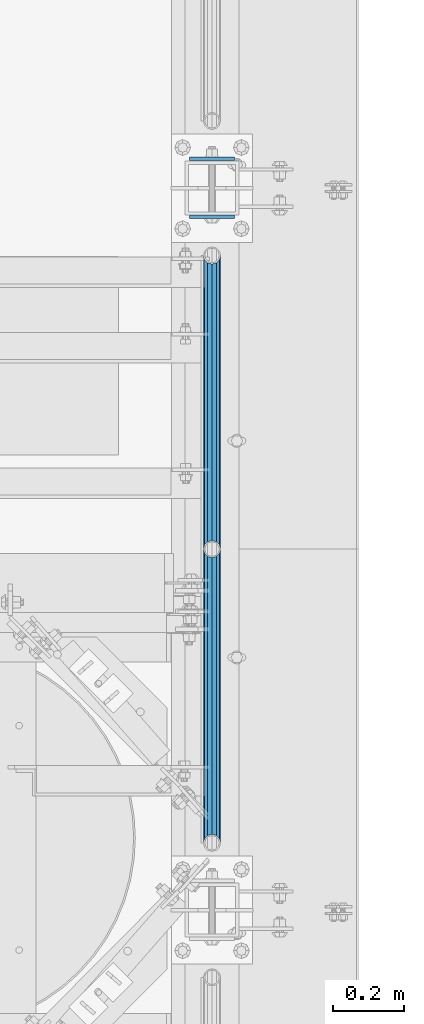
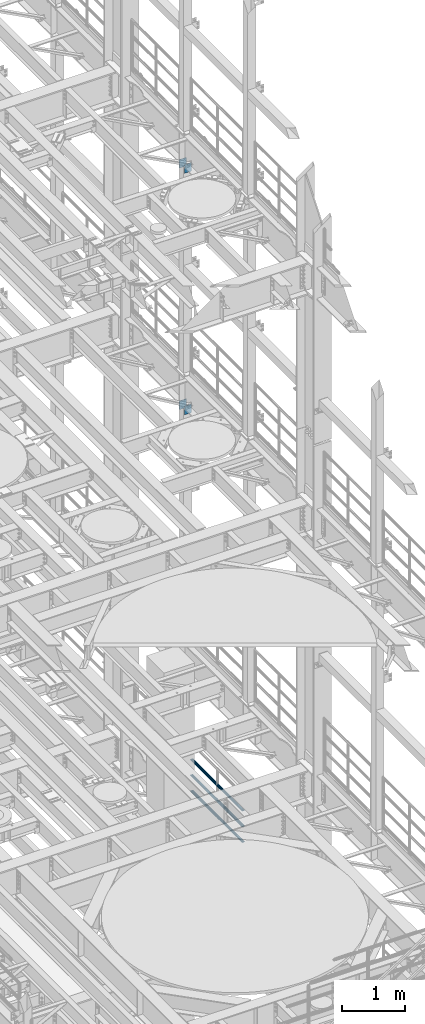
# One storey, part 1281 of 1876: 10 beams, 3 elements without a shape of their own.
"""IFC2X3 building model written with IfcOpenShell, lengths in millimetres."""

from ifc_helpers import new_model, si_unit, frame, origin_with_axes, place, context, subcontext, project, spatial, faceted_brep, material, type_object, element, aggregate, save


model = new_model("IFC2X3")

# Units and contexts
model_context = context("Model", 3, precision=1e-05, world=origin_with_axes())
body_context = subcontext(model_context, "Body", "Model", "MODEL_VIEW")
ifc_project = project(units=[si_unit("LENGTHUNIT", "METRE", prefix="MILLI"), si_unit("AREAUNIT", "SQUARE_METRE"), si_unit("VOLUMEUNIT", "CUBIC_METRE"), si_unit("MASSUNIT", "GRAM", prefix="KILO"), si_unit("TIMEUNIT", "SECOND"), si_unit("PLANEANGLEUNIT", "RADIAN"), si_unit("SOLIDANGLEUNIT", "STERADIAN"), si_unit("THERMODYNAMICTEMPERATUREUNIT", "DEGREE_CELSIUS"), si_unit("LUMINOUSINTENSITYUNIT", "LUMEN")], contexts=[model_context])

# Site, building, storey
site_placement = place(None, origin_with_axes())
site = spatial("IfcSite", under=ifc_project, at=site_placement, CompositionType="ELEMENT")
building_placement = place(site_placement, origin_with_axes())
building = spatial("IfcBuilding", under=site, at=building_placement, Name="Undefined", CompositionType="ELEMENT")
storey_placement = place(building_placement, origin_with_axes())
storey = spatial("IfcBuildingStorey", under=building, at=storey_placement, Name="Undefined", CompositionType="ELEMENT", Elevation=0.0)

# Assembly, beams
assembly_1_placement = place(storey_placement, origin_with_axes())
assembly_1 = element("IfcElementAssembly", 1, at=assembly_1_placement, inside=storey, Name="RAIL", AssemblyPlace="NOTDEFINED", PredefinedType="RIGID_FRAME")
ifc_material_1 = material()
beam_type_1 = type_object("IfcBeamType", Name="PIPE1-1/2SCH40", PredefinedType="NOTDEFINED")
beam_1_placement = place(assembly_1_placement, frame((7620.0, 4572.0, 5292.725), z_axis=(0.0, 0.0, 1.0), x_axis=(0.0, -1.0, 0.0)))
beam_1 = element("IfcBeam", 2, at=beam_1_placement, type_object=beam_type_1, material=ifc_material_1, Name="RAIL", ObjectType="PIPE1-1/2SCH40", context=body_context, shape_type="Brep", body=[
    faceted_brep([(805.872807006681, -12.0649999999996, 20.8971929933177), (805.872807006683, -12.0649999999996, 15.8661214311796), (805.379378568819, -10.2235000000001, 17.7076214311819), (802.640000000001, 0.0, 20.4470000000001), (802.640000000001, 0.0, 24.130000000001), (805.379378568819, 10.2235000000001, 17.7076214311819), (805.872807006683, 12.0649999999996, 15.8661214311796), (805.872807006681, 12.0649999999996, 20.8971929933177), (826.77, 24.1300000000001, 0.0), (814.705, 20.8971929933186, 12.0649999999987), (814.705, 20.8971929933186, -12.0649999999987), (811.515428437862, 17.7076214311801, 10.2235000000001), (814.254807006682, 20.4470000000001, 0.0), (811.515428437862, 17.7076214311801, -10.2235000000001), (805.872807006683, 12.0649999999996, -15.8661214311796), (805.872807006681, 12.0649999999996, -20.8971929933177), (805.379378568819, 10.2235000000001, -17.7076214311819), (802.640000000001, 0.0, -20.4470000000001), (802.640000000001, 0.0, -24.130000000001), (805.872807006683, -12.0649999999996, -15.8661214311796), (805.872807006681, -12.0649999999996, -20.8971929933177), (805.379378568819, -10.2235000000001, -17.7076214311819), (826.77, -24.1300000000001, 0.0), (814.705, -20.8971929933186, -12.0649999999987), (814.705, -20.8971929933186, 12.0649999999987), (811.515428437862, -17.7076214311801, -10.2235000000001), (814.254807006682, -20.4470000000001, 0.0), (811.515428437862, -17.7076214311801, 10.2235000000001), (12.0650000000064, -20.8971929933177, -12.0649999999987), (20.8971929933249, -12.0650000000005, -20.8971929933177), (0.0, 24.1299999999992, 0.0), (12.0650000000064, 20.8971929933177, -12.0649999999987), (12.0650000000064, 20.8971929933177, 12.0649999999987), (20.8971929933249, 12.0650000000005, 20.8971929933177), (24.1300000000064, 0.0, 24.130000000001), (20.8971929933249, 12.0650000000005, -20.8971929933177), (24.1300000000063, 0.0, -24.130000000001), (24.1300000000063, 0.0, -20.4470000000001), (20.8971929933249, -12.0650000000005, -15.8661214311796), (21.3906214311868, -10.2235000000001, -17.7076214311819), (21.3906214311868, 10.2235000000001, -17.7076214311819), (20.8971929933249, 12.0650000000005, -15.8661214311796), (15.2545715621445, 17.7076214311801, -10.2235000000001), (12.5151929933249, 20.4470000000001, 0.0), (15.2545715621445, 17.7076214311801, 10.2235000000001), (20.8971929933249, 12.0650000000005, 15.8661214311796), (21.3906214311868, 10.2235000000001, 17.7076214311819), (24.1300000000064, 0.0, 20.4470000000001), (21.3906214311868, -10.2235000000001, 17.7076214311819), (20.8971929933249, -12.0650000000005, 15.8661214311796), (20.8971929933249, -12.0650000000005, 20.8971929933177), (12.0650000000064, -20.8971929933177, 12.0649999999987), (0.0, -24.1299999999992, 0.0), (15.2545715621445, -17.7076214311801, 10.2235000000001), (12.5151929933249, -20.4470000000001, 0.0), (15.2545715621445, -17.7076214311801, -10.2235000000001)], [[[0, 1, 2, 3, 4]], [[4, 3, 5, 6, 7]], [[8, 9, 10]], [[7, 6, 11, 12, 13, 14, 15, 10, 9]], [[16, 17, 18, 15, 14]], [[19, 20, 18, 17, 21]], [[22, 23, 24]], [[24, 23, 20, 19, 25, 26, 27, 1, 0]], [[28, 29, 20, 23]], [[30, 31, 32]], [[33, 34, 4, 7]], [[32, 33, 7, 9]], [[30, 32, 9, 8]], [[31, 30, 8, 10]], [[35, 31, 10, 15]], [[36, 35, 15, 18]], [[29, 36, 18, 20]], [[37, 36, 29, 38, 39]], [[40, 41, 35, 36, 37]], [[32, 31, 35, 41, 42, 43, 44, 45, 33]], [[33, 45, 46, 47, 34]], [[34, 47, 48, 49, 50]], [[34, 50, 0, 4]], [[50, 51, 24, 0]], [[51, 52, 22, 24]], [[52, 28, 23, 22]], [[51, 28, 52]], [[50, 49, 53, 54, 55, 38, 29, 28, 51]], [[55, 54, 26, 25]], [[21, 39, 38, 55, 25, 19]], [[37, 39, 21, 17]], [[40, 37, 17, 16]], [[42, 41, 40, 16, 14, 13]], [[43, 42, 13, 12]], [[44, 43, 12, 11]], [[5, 46, 45, 44, 11, 6]], [[47, 46, 5, 3]], [[48, 47, 3, 2]], [[53, 49, 48, 2, 1, 27]], [[54, 53, 27, 26]]]),
])
beam_2_placement = place(assembly_1_placement, frame((7620.0, 5398.77, 5292.725), z_axis=(0.0, 0.0, 1.0), x_axis=(0.0, -1.0, 0.0)))
beam_2 = element("IfcBeam", 3, at=beam_2_placement, type_object=beam_type_1, material=ifc_material_1, Name="RAIL", ObjectType="PIPE1-1/2SCH40", context=body_context, shape_type="Brep", body=[
    faceted_brep([(805.872807006681, -12.0649999999996, 20.8971929933177), (805.872807006683, -12.0649999999996, 15.8661214311796), (805.379378568819, -10.2235000000001, 17.7076214311819), (802.640000000001, 0.0, 20.4470000000001), (802.640000000001, 0.0, 24.130000000001), (805.379378568819, 10.2235000000001, 17.7076214311819), (805.872807006683, 12.0649999999996, 15.8661214311796), (805.872807006681, 12.0649999999996, 20.8971929933177), (826.77, 24.1300000000001, 0.0), (814.705, 20.8971929933186, 12.0649999999987), (814.705, 20.8971929933186, -12.0649999999987), (811.515428437862, 17.7076214311801, 10.2235000000001), (814.254807006682, 20.4470000000001, 0.0), (811.515428437862, 17.7076214311801, -10.2235000000001), (805.872807006683, 12.0649999999996, -15.8661214311796), (805.872807006681, 12.0649999999996, -20.8971929933177), (805.379378568819, 10.2235000000001, -17.7076214311819), (802.640000000001, 0.0, -20.4470000000001), (802.640000000001, 0.0, -24.130000000001), (805.872807006683, -12.0649999999996, -15.8661214311796), (805.872807006681, -12.0649999999996, -20.8971929933177), (805.379378568819, -10.2235000000001, -17.7076214311819), (826.77, -24.1300000000001, 0.0), (814.705, -20.8971929933186, -12.0649999999987), (814.705, -20.8971929933186, 12.0649999999987), (811.515428437862, -17.7076214311801, -10.2235000000001), (814.254807006682, -20.4470000000001, 0.0), (811.515428437862, -17.7076214311801, 10.2235000000001), (12.0650000000064, -20.8971929933177, -12.0649999999987), (20.8971929933249, -12.0650000000005, -20.8971929933177), (0.0, 24.1299999999992, 0.0), (12.0650000000064, 20.8971929933177, -12.0649999999987), (12.0650000000064, 20.8971929933177, 12.0649999999987), (20.8971929933249, 12.0650000000005, 20.8971929933177), (24.1300000000064, 0.0, 24.130000000001), (20.8971929933249, 12.0650000000005, -20.8971929933177), (24.1300000000063, 0.0, -24.130000000001), (24.1300000000063, 0.0, -20.4470000000001), (20.8971929933249, -12.0650000000005, -15.8661214311796), (21.3906214311868, -10.2235000000001, -17.7076214311819), (21.3906214311868, 10.2235000000001, -17.7076214311819), (20.8971929933249, 12.0650000000005, -15.8661214311796), (15.2545715621445, 17.7076214311801, -10.2235000000001), (12.5151929933249, 20.4470000000001, 0.0), (15.2545715621445, 17.7076214311801, 10.2235000000001), (20.8971929933249, 12.0650000000005, 15.8661214311796), (21.3906214311868, 10.2235000000001, 17.7076214311819), (24.1300000000064, 0.0, 20.4470000000001), (21.3906214311868, -10.2235000000001, 17.7076214311819), (20.8971929933249, -12.0650000000005, 15.8661214311796), (20.8971929933249, -12.0650000000005, 20.8971929933177), (12.0650000000064, -20.8971929933177, 12.0649999999987), (0.0, -24.1299999999992, 0.0), (15.2545715621445, -17.7076214311801, 10.2235000000001), (12.5151929933249, -20.4470000000001, 0.0), (15.2545715621445, -17.7076214311801, -10.2235000000001)], [[[0, 1, 2, 3, 4]], [[4, 3, 5, 6, 7]], [[8, 9, 10]], [[7, 6, 11, 12, 13, 14, 15, 10, 9]], [[16, 17, 18, 15, 14]], [[19, 20, 18, 17, 21]], [[22, 23, 24]], [[24, 23, 20, 19, 25, 26, 27, 1, 0]], [[28, 29, 20, 23]], [[30, 31, 32]], [[33, 34, 4, 7]], [[32, 33, 7, 9]], [[30, 32, 9, 8]], [[31, 30, 8, 10]], [[35, 31, 10, 15]], [[36, 35, 15, 18]], [[29, 36, 18, 20]], [[37, 36, 29, 38, 39]], [[40, 41, 35, 36, 37]], [[32, 31, 35, 41, 42, 43, 44, 45, 33]], [[33, 45, 46, 47, 34]], [[34, 47, 48, 49, 50]], [[34, 50, 0, 4]], [[50, 51, 24, 0]], [[51, 52, 22, 24]], [[52, 28, 23, 22]], [[51, 28, 52]], [[50, 49, 53, 54, 55, 38, 29, 28, 51]], [[55, 54, 26, 25]], [[21, 39, 38, 55, 25, 19]], [[37, 39, 21, 17]], [[40, 37, 17, 16]], [[42, 41, 40, 16, 14, 13]], [[43, 42, 13, 12]], [[44, 43, 12, 11]], [[5, 46, 45, 44, 11, 6]], [[47, 46, 5, 3]], [[48, 47, 3, 2]], [[53, 49, 48, 2, 1, 27]], [[54, 53, 27, 26]]]),
])
beam_3_placement = place(assembly_1_placement, frame((7620.0, 3745.23, 5597.525), z_axis=(0.0, 0.0, -1.0), x_axis=(0.0, 1.0, 0.0)))
beam_3 = element("IfcBeam", 4, at=beam_3_placement, type_object=beam_type_1, material=ifc_material_1, Name="RAIL", ObjectType="PIPE1-1/2SCH40", context=body_context, shape_type="Brep", body=[
    faceted_brep([(0.0, 24.1299999999992, 0.0), (12.0650000000064, 20.8971929933177, -12.0649999999987), (12.0650000000064, 20.8971929933177, 12.0649999999987), (12.0650000000064, -20.8971929933177, 12.0649999999987), (12.0650000000064, -20.8971929933177, -12.0649999999987), (0.0, -24.1299999999992, 0.0), (20.8971929933249, -12.0650000000005, 20.8971929933177), (20.8971929933249, -12.0650000000005, 15.8661214311796), (15.2545715621445, -17.7076214311801, 10.2235000000001), (12.5151929933249, -20.4470000000001, 0.0), (15.2545715621445, -17.7076214311801, -10.2235000000001), (20.8971929933249, -12.0650000000005, -15.8661214311796), (20.8971929933249, -12.0650000000005, -20.8971929933177), (24.1300000000063, 0.0, -20.4470000000001), (24.1300000000063, 0.0, -24.130000000001), (21.3906214311868, -10.2235000000001, -17.7076214311819), (21.3906214311868, 10.2235000000001, -17.7076214311819), (20.8971929933249, 12.0650000000005, -15.8661214311796), (20.8971929933249, 12.0650000000005, -20.8971929933177), (15.2545715621445, 17.7076214311801, -10.2235000000001), (12.5151929933249, 20.4470000000001, 0.0), (15.2545715621445, 17.7076214311801, 10.2235000000001), (20.8971929933249, 12.0650000000005, 15.8661214311796), (20.8971929933249, 12.0650000000005, 20.8971929933177), (21.3906214311868, 10.2235000000001, 17.7076214311819), (24.1300000000064, 0.0, 20.4470000000001), (24.1300000000064, 0.0, 24.130000000001), (21.3906214311868, -10.2235000000001, 17.7076214311819), (826.77, 24.1300000000001, 0.0), (814.705, 20.8971929933186, -12.0649999999987), (805.872807006681, 12.0649999999996, -20.8971929933177), (826.77, -24.1300000000001, 0.0), (814.705, -20.8971929933186, -12.0649999999987), (814.705, -20.8971929933186, 12.0649999999987), (805.872807006681, -12.0649999999996, 20.8971929933177), (805.872807006681, -12.0649999999996, -20.8971929933177), (802.640000000001, 0.0, -24.130000000001), (805.379378568819, 10.2235000000001, -17.7076214311819), (802.640000000001, 0.0, -20.4470000000001), (805.872807006683, 12.0649999999996, -15.8661214311796), (805.872807006683, -12.0649999999996, -15.8661214311796), (805.379378568819, -10.2235000000001, -17.7076214311819), (811.515428437862, -17.7076214311801, -10.2235000000001), (814.254807006682, -20.4470000000001, 0.0), (811.515428437862, -17.7076214311801, 10.2235000000001), (805.872807006683, -12.0649999999996, 15.8661214311796), (805.379378568819, -10.2235000000001, 17.7076214311819), (802.640000000001, 0.0, 20.4470000000001), (802.640000000001, 0.0, 24.130000000001), (805.872807006681, 12.0649999999996, 20.8971929933177), (814.705, 20.8971929933186, 12.0649999999987), (805.872807006683, 12.0649999999996, 15.8661214311796), (811.515428437862, 17.7076214311801, 10.2235000000001), (814.254807006682, 20.4470000000001, 0.0), (811.515428437862, 17.7076214311801, -10.2235000000001), (805.379378568819, 10.2235000000001, 17.7076214311819)], [[[0, 1, 2]], [[3, 4, 5]], [[6, 7, 8, 9, 10, 11, 12, 4, 3]], [[13, 14, 12, 11, 15]], [[16, 17, 18, 14, 13]], [[2, 1, 18, 17, 19, 20, 21, 22, 23]], [[23, 22, 24, 25, 26]], [[26, 25, 27, 7, 6]], [[1, 0, 28, 29]], [[18, 1, 29, 30]], [[31, 32, 33]], [[6, 3, 33, 34]], [[3, 5, 31, 33]], [[5, 4, 32, 31]], [[4, 12, 35, 32]], [[12, 14, 36, 35]], [[14, 18, 30, 36]], [[37, 38, 36, 30, 39]], [[40, 35, 36, 38, 41]], [[33, 32, 35, 40, 42, 43, 44, 45, 34]], [[34, 45, 46, 47, 48]], [[26, 6, 34, 48]], [[2, 23, 49, 50]], [[23, 26, 48, 49]], [[0, 2, 50, 28]], [[28, 50, 29]], [[49, 51, 52, 53, 54, 39, 30, 29, 50]], [[48, 47, 55, 51, 49]], [[25, 24, 55, 47]], [[55, 24, 22, 21, 52, 51]], [[21, 20, 53, 52]], [[20, 19, 54, 53]], [[19, 17, 16, 37, 39, 54]], [[16, 13, 38, 37]], [[13, 15, 41, 38]], [[41, 15, 11, 10, 42, 40]], [[10, 9, 43, 42]], [[9, 8, 44, 43]], [[8, 7, 27, 46, 45, 44]], [[27, 25, 47, 46]]]),
])
beam_4_placement = place(assembly_1_placement, frame((7620.0, 4572.0, 5597.525), z_axis=(0.0, 0.0, -1.0), x_axis=(0.0, 1.0, 0.0)))
beam_4 = element("IfcBeam", 5, at=beam_4_placement, type_object=beam_type_1, material=ifc_material_1, Name="RAIL", ObjectType="PIPE1-1/2SCH40", context=body_context, shape_type="Brep", body=[
    faceted_brep([(0.0, 24.1299999999992, 0.0), (12.0650000000064, 20.8971929933177, -12.0649999999987), (12.0650000000064, 20.8971929933177, 12.0649999999987), (12.0650000000064, -20.8971929933177, 12.0649999999987), (12.0650000000064, -20.8971929933177, -12.0649999999987), (0.0, -24.1299999999992, 0.0), (20.8971929933249, -12.0650000000005, 20.8971929933177), (20.8971929933249, -12.0650000000005, 15.8661214311796), (15.2545715621445, -17.7076214311801, 10.2235000000001), (12.5151929933249, -20.4470000000001, 0.0), (15.2545715621445, -17.7076214311801, -10.2235000000001), (20.8971929933249, -12.0650000000005, -15.8661214311796), (20.8971929933249, -12.0650000000005, -20.8971929933177), (24.1300000000063, 0.0, -20.4470000000001), (24.1300000000063, 0.0, -24.130000000001), (21.3906214311868, -10.2235000000001, -17.7076214311819), (21.3906214311868, 10.2235000000001, -17.7076214311819), (20.8971929933249, 12.0650000000005, -15.8661214311796), (20.8971929933249, 12.0650000000005, -20.8971929933177), (15.2545715621445, 17.7076214311801, -10.2235000000001), (12.5151929933249, 20.4470000000001, 0.0), (15.2545715621445, 17.7076214311801, 10.2235000000001), (20.8971929933249, 12.0650000000005, 15.8661214311796), (20.8971929933249, 12.0650000000005, 20.8971929933177), (21.3906214311868, 10.2235000000001, 17.7076214311819), (24.1300000000064, 0.0, 20.4470000000001), (24.1300000000064, 0.0, 24.130000000001), (21.3906214311868, -10.2235000000001, 17.7076214311819), (826.77, 24.1300000000001, 0.0), (814.705, 20.8971929933186, -12.0649999999987), (805.872807006681, 12.0649999999996, -20.8971929933177), (826.77, -24.1300000000001, 0.0), (814.705, -20.8971929933186, -12.0649999999987), (814.705, -20.8971929933186, 12.0649999999987), (805.872807006681, -12.0649999999996, 20.8971929933177), (805.872807006681, -12.0649999999996, -20.8971929933177), (802.640000000001, 0.0, -24.130000000001), (805.379378568819, 10.2235000000001, -17.7076214311819), (802.640000000001, 0.0, -20.4470000000001), (805.872807006683, 12.0649999999996, -15.8661214311796), (805.872807006683, -12.0649999999996, -15.8661214311796), (805.379378568819, -10.2235000000001, -17.7076214311819), (811.515428437862, -17.7076214311801, -10.2235000000001), (814.254807006682, -20.4470000000001, 0.0), (811.515428437862, -17.7076214311801, 10.2235000000001), (805.872807006683, -12.0649999999996, 15.8661214311796), (805.379378568819, -10.2235000000001, 17.7076214311819), (802.640000000001, 0.0, 20.4470000000001), (802.640000000001, 0.0, 24.130000000001), (805.872807006681, 12.0649999999996, 20.8971929933177), (814.705, 20.8971929933186, 12.0649999999987), (805.872807006683, 12.0649999999996, 15.8661214311796), (811.515428437862, 17.7076214311801, 10.2235000000001), (814.254807006682, 20.4470000000001, 0.0), (811.515428437862, 17.7076214311801, -10.2235000000001), (805.379378568819, 10.2235000000001, 17.7076214311819)], [[[0, 1, 2]], [[3, 4, 5]], [[6, 7, 8, 9, 10, 11, 12, 4, 3]], [[13, 14, 12, 11, 15]], [[16, 17, 18, 14, 13]], [[2, 1, 18, 17, 19, 20, 21, 22, 23]], [[23, 22, 24, 25, 26]], [[26, 25, 27, 7, 6]], [[1, 0, 28, 29]], [[18, 1, 29, 30]], [[31, 32, 33]], [[6, 3, 33, 34]], [[3, 5, 31, 33]], [[5, 4, 32, 31]], [[4, 12, 35, 32]], [[12, 14, 36, 35]], [[14, 18, 30, 36]], [[37, 38, 36, 30, 39]], [[40, 35, 36, 38, 41]], [[33, 32, 35, 40, 42, 43, 44, 45, 34]], [[34, 45, 46, 47, 48]], [[26, 6, 34, 48]], [[2, 23, 49, 50]], [[23, 26, 48, 49]], [[0, 2, 50, 28]], [[28, 50, 29]], [[49, 51, 52, 53, 54, 39, 30, 29, 50]], [[48, 47, 55, 51, 49]], [[25, 24, 55, 47]], [[55, 24, 22, 21, 52, 51]], [[21, 20, 53, 52]], [[20, 19, 54, 53]], [[19, 17, 16, 37, 39, 54]], [[16, 13, 38, 37]], [[13, 15, 41, 38]], [[41, 15, 11, 10, 42, 40]], [[10, 9, 43, 42]], [[9, 8, 44, 43]], [[8, 7, 27, 46, 45, 44]], [[27, 25, 47, 46]]]),
])
beam_5_placement = place(assembly_1_placement, frame((7620.0, 3745.23, 5902.325), z_axis=(0.0, 0.0, -1.0), x_axis=(0.0, 1.0, 0.0)))
beam_5 = element("IfcBeam", 6, at=beam_5_placement, type_object=beam_type_1, material=ifc_material_1, Name="RAIL", ObjectType="PIPE1-1/2SCH40", context=body_context, shape_type="Brep", body=[
    faceted_brep([(0.0, 24.1299999999992, 0.0), (12.0650000000064, 20.8971929933177, -12.0649999999987), (12.0650000000064, 20.8971929933177, 12.0649999999987), (12.0650000000064, -20.8971929933177, 12.0649999999987), (12.0650000000064, -20.8971929933177, -12.0649999999987), (0.0, -24.1299999999992, 0.0), (20.8971929933249, -12.0650000000005, 20.8971929933177), (20.8971929933249, -12.0650000000005, 15.8661214311796), (15.2545715621445, -17.7076214311801, 10.2235000000001), (12.5151929933249, -20.4470000000001, 0.0), (15.2545715621445, -17.7076214311801, -10.2235000000001), (20.8971929933249, -12.0650000000005, -15.8661214311796), (20.8971929933249, -12.0650000000005, -20.8971929933177), (24.1300000000063, 0.0, -20.4470000000001), (24.1300000000063, 0.0, -24.130000000001), (21.3906214311868, -10.2235000000001, -17.7076214311819), (21.3906214311868, 10.2235000000001, -17.7076214311819), (20.8971929933249, 12.0650000000005, -15.8661214311796), (20.8971929933249, 12.0650000000005, -20.8971929933177), (15.2545715621445, 17.7076214311801, -10.2235000000001), (12.5151929933249, 20.4470000000001, 0.0), (15.2545715621445, 17.7076214311801, 10.2235000000001), (20.8971929933249, 12.0650000000005, 15.8661214311796), (20.8971929933249, 12.0650000000005, 20.8971929933177), (21.3906214311868, 10.2235000000001, 17.7076214311819), (24.1300000000064, 0.0, 20.4470000000001), (24.1300000000064, 0.0, 24.130000000001), (21.3906214311868, -10.2235000000001, 17.7076214311819), (826.77, 24.1300000000001, 0.0), (814.705, 20.8971929933186, -12.0649999999987), (805.872807006681, 12.0649999999996, -20.8971929933177), (826.77, -24.1300000000001, 0.0), (814.705, -20.8971929933186, -12.0649999999987), (814.705, -20.8971929933186, 12.0649999999987), (805.872807006681, -12.0649999999996, 20.8971929933177), (805.872807006681, -12.0649999999996, -20.8971929933177), (802.640000000001, 0.0, -24.130000000001), (805.379378568819, 10.2235000000001, -17.7076214311819), (802.640000000001, 0.0, -20.4470000000001), (805.872807006683, 12.0649999999996, -15.8661214311796), (805.872807006683, -12.0649999999996, -15.8661214311796), (805.379378568819, -10.2235000000001, -17.7076214311819), (811.515428437862, -17.7076214311801, -10.2235000000001), (814.254807006682, -20.4470000000001, 0.0), (811.515428437862, -17.7076214311801, 10.2235000000001), (805.872807006683, -12.0649999999996, 15.8661214311796), (805.379378568819, -10.2235000000001, 17.7076214311819), (802.640000000001, 0.0, 20.4470000000001), (802.640000000001, 0.0, 24.130000000001), (805.872807006681, 12.0649999999996, 20.8971929933177), (814.705, 20.8971929933186, 12.0649999999987), (805.872807006683, 12.0649999999996, 15.8661214311796), (811.515428437862, 17.7076214311801, 10.2235000000001), (814.254807006682, 20.4470000000001, 0.0), (811.515428437862, 17.7076214311801, -10.2235000000001), (805.379378568819, 10.2235000000001, 17.7076214311819)], [[[0, 1, 2]], [[3, 4, 5]], [[6, 7, 8, 9, 10, 11, 12, 4, 3]], [[13, 14, 12, 11, 15]], [[16, 17, 18, 14, 13]], [[2, 1, 18, 17, 19, 20, 21, 22, 23]], [[23, 22, 24, 25, 26]], [[26, 25, 27, 7, 6]], [[1, 0, 28, 29]], [[18, 1, 29, 30]], [[31, 32, 33]], [[6, 3, 33, 34]], [[3, 5, 31, 33]], [[5, 4, 32, 31]], [[4, 12, 35, 32]], [[12, 14, 36, 35]], [[14, 18, 30, 36]], [[37, 38, 36, 30, 39]], [[40, 35, 36, 38, 41]], [[33, 32, 35, 40, 42, 43, 44, 45, 34]], [[34, 45, 46, 47, 48]], [[26, 6, 34, 48]], [[2, 23, 49, 50]], [[23, 26, 48, 49]], [[0, 2, 50, 28]], [[28, 50, 29]], [[49, 51, 52, 53, 54, 39, 30, 29, 50]], [[48, 47, 55, 51, 49]], [[25, 24, 55, 47]], [[55, 24, 22, 21, 52, 51]], [[21, 20, 53, 52]], [[20, 19, 54, 53]], [[19, 17, 16, 37, 39, 54]], [[16, 13, 38, 37]], [[13, 15, 41, 38]], [[41, 15, 11, 10, 42, 40]], [[10, 9, 43, 42]], [[9, 8, 44, 43]], [[8, 7, 27, 46, 45, 44]], [[27, 25, 47, 46]]]),
])
beam_6_placement = place(assembly_1_placement, frame((7620.0, 4572.0, 5902.325), z_axis=(0.0, 0.0, -1.0), x_axis=(0.0, 1.0, 0.0)))
beam_6 = element("IfcBeam", 7, at=beam_6_placement, type_object=beam_type_1, material=ifc_material_1, Name="RAIL", ObjectType="PIPE1-1/2SCH40", context=body_context, shape_type="Brep", body=[
    faceted_brep([(0.0, 24.1299999999992, 0.0), (12.0650000000064, 20.8971929933177, -12.0649999999987), (12.0650000000064, 20.8971929933177, 12.0649999999987), (12.0650000000064, -20.8971929933177, 12.0649999999987), (12.0650000000064, -20.8971929933177, -12.0649999999987), (0.0, -24.1299999999992, 0.0), (20.8971929933249, -12.0650000000005, 20.8971929933177), (20.8971929933249, -12.0650000000005, 15.8661214311796), (15.2545715621445, -17.7076214311801, 10.2235000000001), (12.5151929933249, -20.4470000000001, 0.0), (15.2545715621445, -17.7076214311801, -10.2235000000001), (20.8971929933249, -12.0650000000005, -15.8661214311796), (20.8971929933249, -12.0650000000005, -20.8971929933177), (24.1300000000063, 0.0, -20.4470000000001), (24.1300000000063, 0.0, -24.130000000001), (21.3906214311868, -10.2235000000001, -17.7076214311819), (21.3906214311868, 10.2235000000001, -17.7076214311819), (20.8971929933249, 12.0650000000005, -15.8661214311796), (20.8971929933249, 12.0650000000005, -20.8971929933177), (15.2545715621445, 17.7076214311801, -10.2235000000001), (12.5151929933249, 20.4470000000001, 0.0), (15.2545715621445, 17.7076214311801, 10.2235000000001), (20.8971929933249, 12.0650000000005, 15.8661214311796), (20.8971929933249, 12.0650000000005, 20.8971929933177), (21.3906214311868, 10.2235000000001, 17.7076214311819), (24.1300000000064, 0.0, 20.4470000000001), (24.1300000000064, 0.0, 24.130000000001), (21.3906214311868, -10.2235000000001, 17.7076214311819), (826.77, 24.1300000000001, 0.0), (814.705, 20.8971929933186, -12.0649999999987), (805.872807006681, 12.0649999999996, -20.8971929933177), (826.77, -24.1300000000001, 0.0), (814.705, -20.8971929933186, -12.0649999999987), (814.705, -20.8971929933186, 12.0649999999987), (805.872807006681, -12.0649999999996, 20.8971929933177), (805.872807006681, -12.0649999999996, -20.8971929933177), (802.640000000001, 0.0, -24.130000000001), (805.379378568819, 10.2235000000001, -17.7076214311819), (802.640000000001, 0.0, -20.4470000000001), (805.872807006683, 12.0649999999996, -15.8661214311796), (805.872807006683, -12.0649999999996, -15.8661214311796), (805.379378568819, -10.2235000000001, -17.7076214311819), (811.515428437862, -17.7076214311801, -10.2235000000001), (814.254807006682, -20.4470000000001, 0.0), (811.515428437862, -17.7076214311801, 10.2235000000001), (805.872807006683, -12.0649999999996, 15.8661214311796), (805.379378568819, -10.2235000000001, 17.7076214311819), (802.640000000001, 0.0, 20.4470000000001), (802.640000000001, 0.0, 24.130000000001), (805.872807006681, 12.0649999999996, 20.8971929933177), (814.705, 20.8971929933186, 12.0649999999987), (805.872807006683, 12.0649999999996, 15.8661214311796), (811.515428437862, 17.7076214311801, 10.2235000000001), (814.254807006682, 20.4470000000001, 0.0), (811.515428437862, 17.7076214311801, -10.2235000000001), (805.379378568819, 10.2235000000001, 17.7076214311819)], [[[0, 1, 2]], [[3, 4, 5]], [[6, 7, 8, 9, 10, 11, 12, 4, 3]], [[13, 14, 12, 11, 15]], [[16, 17, 18, 14, 13]], [[2, 1, 18, 17, 19, 20, 21, 22, 23]], [[23, 22, 24, 25, 26]], [[26, 25, 27, 7, 6]], [[1, 0, 28, 29]], [[18, 1, 29, 30]], [[31, 32, 33]], [[6, 3, 33, 34]], [[3, 5, 31, 33]], [[5, 4, 32, 31]], [[4, 12, 35, 32]], [[12, 14, 36, 35]], [[14, 18, 30, 36]], [[37, 38, 36, 30, 39]], [[40, 35, 36, 38, 41]], [[33, 32, 35, 40, 42, 43, 44, 45, 34]], [[34, 45, 46, 47, 48]], [[26, 6, 34, 48]], [[2, 23, 49, 50]], [[23, 26, 48, 49]], [[0, 2, 50, 28]], [[28, 50, 29]], [[49, 51, 52, 53, 54, 39, 30, 29, 50]], [[48, 47, 55, 51, 49]], [[25, 24, 55, 47]], [[55, 24, 22, 21, 52, 51]], [[21, 20, 53, 52]], [[20, 19, 54, 53]], [[19, 17, 16, 37, 39, 54]], [[16, 13, 38, 37]], [[13, 15, 41, 38]], [[41, 15, 11, 10, 42, 40]], [[10, 9, 43, 42]], [[9, 8, 44, 43]], [[8, 7, 27, 46, 45, 44]], [[27, 25, 47, 46]]]),
])
aggregate(assembly_1, [beam_1, beam_2, beam_3, beam_4, beam_5, beam_6])

assembly_2_placement = place(storey_placement, origin_with_axes())
assembly_2 = element("IfcElementAssembly", 8, at=assembly_2_placement, inside=storey, Name="BEAM", AssemblyPlace="NOTDEFINED", PredefinedType="RIGID_FRAME")
ifc_material_2 = material(Name="STEEL/A36")
beam_type_2 = type_object("IfcBeamType", PredefinedType="NOTDEFINED")
beam_7_placement = place(assembly_2_placement, frame((7556.36848042001, 5670.55, 12604.7488224823), z_axis=(2.95459999824743e-05, 0.0, -0.999999999563517), x_axis=(0.999999999563517, 0.0, 2.95459999828704e-05)))
beam_7 = element("IfcBeam", 9, at=beam_7_placement, type_object=beam_type_2, material=ifc_material_2, Name="PLATE", context=body_context, shape_type="Brep", body=[
    faceted_brep([(0.0, 4.76249999999982, -82.5499999999993), (0.0, 4.76249999999982, 82.5499999999993), (127.0, 4.76249999999982, 82.5499999999993), (127.0, 4.76249999999982, -82.5499999999993), (0.0, -4.76249999999982, 82.5499999999993), (127.0, -4.76249999999982, 82.5499999999993), (0.0, -4.76249999999982, -82.5499999999993), (127.0, -4.76249999999982, -82.5499999999993)], [[[0, 1, 2, 3]], [[1, 4, 5, 2]], [[4, 6, 7, 5]], [[6, 0, 3, 7]], [[5, 7, 3, 2]], [[6, 4, 1, 0]]]),
])
beam_8_placement = place(assembly_2_placement, frame((7556.36848042001, 5507.0375, 12604.7488224823), z_axis=(2.95459999824743e-05, 0.0, -0.999999999563517), x_axis=(0.999999999563517, 0.0, 2.95459999828704e-05)))
beam_8 = element("IfcBeam", 10, at=beam_8_placement, type_object=beam_type_2, material=ifc_material_2, Name="PLATE", context=body_context, shape_type="Brep", body=[
    faceted_brep([(0.0, 4.76249999999982, -82.5499999999993), (0.0, 4.76249999999982, 82.5499999999993), (127.0, 4.76249999999982, 82.5499999999993), (127.0, 4.76249999999982, -82.5499999999993), (0.0, -4.76249999999982, 82.5499999999993), (127.0, -4.76249999999982, 82.5499999999993), (0.0, -4.76249999999982, -82.5499999999993), (127.0, -4.76249999999982, -82.5499999999993)], [[[0, 1, 2, 3]], [[1, 4, 5, 2]], [[4, 6, 7, 5]], [[6, 0, 3, 7]], [[5, 7, 3, 2]], [[6, 4, 1, 0]]]),
])
aggregate(assembly_2, [beam_7, beam_8])

assembly_3_placement = place(storey_placement, origin_with_axes())
assembly_3 = element("IfcElementAssembly", 11, at=assembly_3_placement, inside=storey, Name="BEAM", AssemblyPlace="NOTDEFINED", PredefinedType="RIGID_FRAME")
beam_9_placement = place(assembly_3_placement, frame((7556.5, 5670.55, 17278.35), z_axis=(0.0, 0.0, -1.0), x_axis=(1.0, 0.0, 0.0)))
beam_9 = element("IfcBeam", 12, at=beam_9_placement, type_object=beam_type_2, material=ifc_material_2, Name="PLATE", context=body_context, shape_type="Brep", body=[
    faceted_brep([(0.0, 4.76249999999982, -82.5499999999993), (0.0, 4.76249999999982, 82.5499999999993), (127.0, 4.76249999999982, 82.5499999999993), (127.0, 4.76249999999982, -82.5499999999993), (0.0, -4.76249999999982, 82.5499999999993), (127.0, -4.76249999999982, 82.5499999999993), (0.0, -4.76249999999982, -82.5499999999993), (127.0, -4.76249999999982, -82.5499999999993)], [[[0, 1, 2, 3]], [[1, 4, 5, 2]], [[4, 6, 7, 5]], [[6, 0, 3, 7]], [[5, 7, 3, 2]], [[6, 4, 1, 0]]]),
])
beam_10_placement = place(assembly_3_placement, frame((7556.5, 5507.0375, 17278.35), z_axis=(0.0, 0.0, -1.0), x_axis=(1.0, 0.0, 0.0)))
beam_10 = element("IfcBeam", 13, at=beam_10_placement, type_object=beam_type_2, material=ifc_material_2, Name="PLATE", context=body_context, shape_type="Brep", body=[
    faceted_brep([(0.0, 4.76249999999982, -82.5499999999993), (0.0, 4.76249999999982, 82.5499999999993), (127.0, 4.76249999999982, 82.5499999999993), (127.0, 4.76249999999982, -82.5499999999993), (0.0, -4.76249999999982, 82.5499999999993), (127.0, -4.76249999999982, 82.5499999999993), (0.0, -4.76249999999982, -82.5499999999993), (127.0, -4.76249999999982, -82.5499999999993)], [[[0, 1, 2, 3]], [[1, 4, 5, 2]], [[4, 6, 7, 5]], [[6, 0, 3, 7]], [[5, 7, 3, 2]], [[6, 4, 1, 0]]]),
])
aggregate(assembly_3, [beam_9, beam_10])

save(model, "model.ifc")
